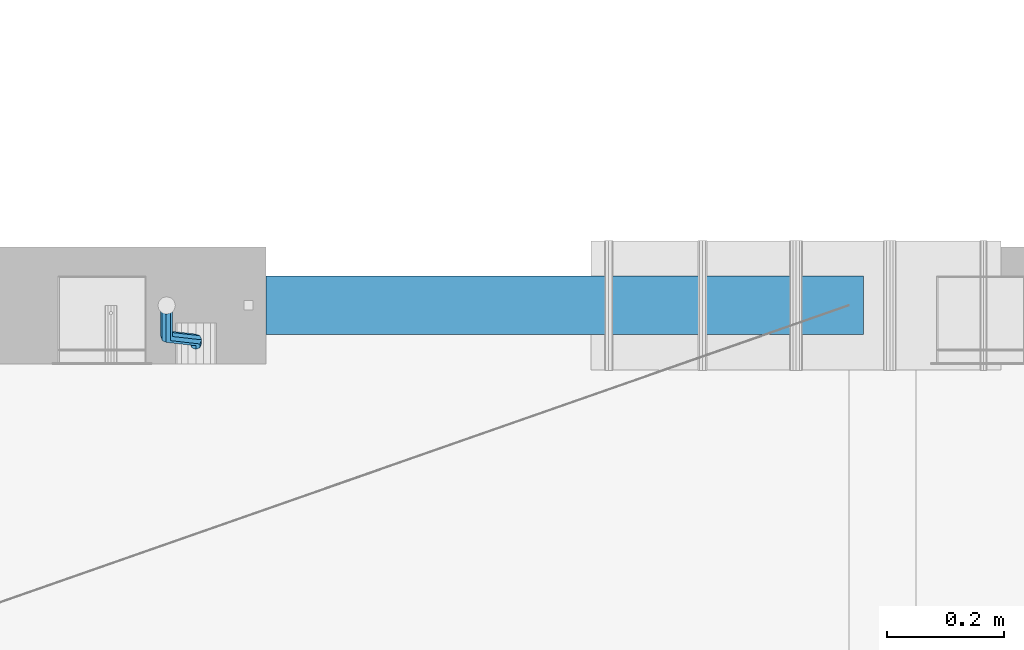
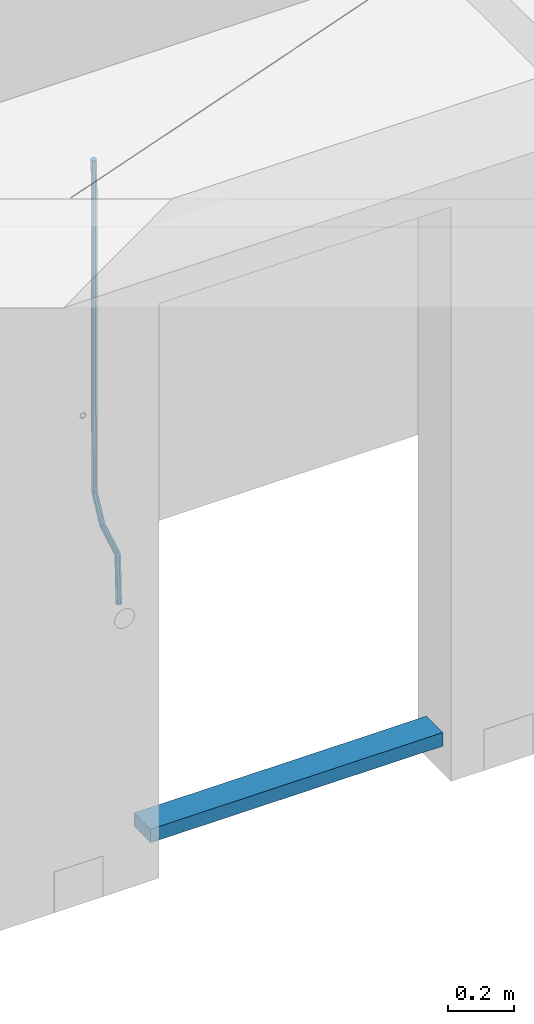
# One storey, part 107 of 341: 2 beams, 1 element without a shape of its own.
"""IFC2X3 building model written with IfcOpenShell, lengths in millimetres."""

from ifc_helpers import new_model, si_unit, frame, origin_with_axes, place, context, subcontext, project, spatial, faceted_brep, material, type_object, element, aggregate, save


model = new_model("IFC2X3")

# Units and contexts
model_context = context("Model", 3, precision=1e-05, world=origin_with_axes())
body_context = subcontext(model_context, "Body", "Model", "MODEL_VIEW")
ifc_project = project(units=[si_unit("LENGTHUNIT", "METRE", prefix="MILLI"), si_unit("AREAUNIT", "SQUARE_METRE"), si_unit("VOLUMEUNIT", "CUBIC_METRE"), si_unit("MASSUNIT", "GRAM", prefix="KILO"), si_unit("TIMEUNIT", "SECOND"), si_unit("PLANEANGLEUNIT", "RADIAN"), si_unit("SOLIDANGLEUNIT", "STERADIAN"), si_unit("THERMODYNAMICTEMPERATUREUNIT", "DEGREE_CELSIUS"), si_unit("LUMINOUSINTENSITYUNIT", "LUMEN")], contexts=[model_context])

# Site, building, storey
site_placement = place(None, origin_with_axes())
site = spatial("IfcSite", under=ifc_project, at=site_placement, CompositionType="ELEMENT")
building_placement = place(site_placement, origin_with_axes())
building = spatial("IfcBuilding", under=site, at=building_placement, CompositionType="ELEMENT")
storey_placement = place(building_placement, origin_with_axes())
storey = spatial("IfcBuildingStorey", under=building, at=storey_placement, Name="5", CompositionType="ELEMENT", Elevation=0.0)

# Assembly, beams
assembly_placement = place(storey_placement, origin_with_axes())
assembly = element("IfcElementAssembly", 1, at=assembly_placement, inside=storey, AssemblyPlace="NOTDEFINED", PredefinedType="REINFORCEMENT_UNIT")
ifc_material_1 = material()
beam_type_1 = type_object("IfcBeamType", Name="D20", PredefinedType="NOTDEFINED")
beam_1_placement = place(assembly_placement, frame((24379.9991455117, 15114.989587991, 94790.0076324386), z_axis=(-0.000205762999925498, 0.999642804629538, -0.0267249099901004), x_axis=(4.30000201928125e-08, 0.0267249099948059, 0.999642825806181)))
beam_1 = element("IfcBeam", 2, at=beam_1_placement, type_object=beam_type_1, material=ifc_material_1, Name="JM20", ObjectType="D20", context=body_context, shape_type="Brep", body=[
    faceted_brep([(0.0, -10.0, 0.0), (-4.19531716033816e-08, -7.07106781186667, -7.07106781187031), (60.4266690400545, -7.0710677960451, -7.07106780570757), (60.4266690441291, -9.99999998418934, 6.15546014159918e-09), (0.0, 0.0, -10.0), (60.426669036824, 1.58106558956206e-08, -9.99999999384454), (4.196772351861e-08, 7.07106781186303, -7.07106781186667), (60.4266690363438, 7.07106782768096, -7.07106780570757), (0.0, 10.0, 0.0), (60.4266690388904, 10.0000000158179, 6.15182216279209e-09), (4.196772351861e-08, 7.07106781185939, 7.07106781185939), (60.4266690429649, 7.07106782768096, 7.07106781802577), (0.0, 0.0, 10.0), (60.4266690461809, 1.58179318532348e-08, 10.0000000061555), (-4.19531716033816e-08, -7.07106781187031, 7.07106781185939), (60.4266690466611, -7.07106779605238, 7.07106781802213), (61.0378400410118, -7.07106779588503, -7.07106780564936), (60.991799419251, -9.99999998403655, 6.21366780251265e-09), (61.0569027789461, 1.5985278878361e-08, -9.99999999378269), (61.0378209396877, 7.07106782784831, -7.07106780564936), (60.9917724058905, 10.0000000159635, 6.21366780251265e-09), (60.9457317841297, 7.07106782781193, 7.0710678180767), (60.9266690461809, 1.59488990902901e-08, 10.0000000062028), (60.9457508854539, -7.07106779591413, 7.0710678180767), (61.6489592143771, -7.07106614513759, -7.06310863441468), (61.5568818710308, -9.9999984576425, 0.00735959856683621), (61.6870830769039, 1.71821739058942e-06, -9.99179257185824), (61.6489210170112, 7.07106947854481, -7.06310888312146), (61.556827851804, 10.0000015422847, 0.00735924683976918), (61.4647505084577, 7.07106922979438, 7.07782747982128), (61.4266266459163, 1.36643211590126e-06, 10.0065114172685), (61.464788705809, -7.07106639389531, 7.07782772852806), (174.621213165461, -7.07076098345351, -5.59176629582907), (174.529135822144, -9.99969329595478, 1.4787019371488), (174.659337027944, 0.000306879905110691, -8.52045023327446), (174.621174967935, 7.07137464022526, -5.59176654453404), (174.529081802684, 10.0003067039688, 1.47870158543083), (174.437004459352, 7.07137439147118, 8.5491698184087), (174.398880596913, 0.000306528108922066, 11.4778537558541), (174.437042656878, -7.07076123221123, 8.54917006711185), (175.716094779258, -7.07075802595864, -5.57750663810293), (175.029093421879, -9.99969194546793, 1.48521334821271), (177.145578432857, 0.000313595744955819, -8.48806960781258), (178.480172245545, 7.07138506415868, -5.54150724740612), (178.938089262141, 10.0003186135946, 1.53612417477052), (178.251087904748, 7.07138469408164, 8.59884416108434), (176.821604251149, 0.000313072378048673, 11.5094071307958), (175.487010438475, -7.07075839603567, 8.56284477038935), (176.73028205616, -7.48306481911277, -5.5575978012148), (175.49220343327, -10.1879642774365, 1.49430435328395), (179.448580299344, -0.935946733912715, -8.44286090764945), (182.054755918522, 5.61817699831226, -5.47133696928722), (183.022146581905, 8.33998958468874, 1.61629559169705), (181.784067959001, 5.63509012636496, 8.6681977461958), (179.065769715831, -0.912027958831459, 11.5534608526305), (176.459594096654, -7.4661516910528, 8.58193691426459), (294.295456565174, -55.2779062578775, -3.24975393820569), (293.057377942285, -57.9828057162013, 3.80214821629306), (297.013754808359, -48.7307881726811, -6.13501704463852), (299.619930427536, -42.1766644404597, -3.16349310627629), (300.587321090919, -39.454851854076, 3.92413945470616), (299.34924246803, -42.1597513124034, 10.9760416092031), (296.630944224846, -48.7068693975998, 13.8613047156396), (294.024768605668, -55.2609931298248, 10.8897807772755), (300.131186042752, -57.6503585272258, -3.13519660847487), (297.927214299008, -59.9625846556301, 3.89774473963917), (302.241773597852, -50.8561822796182, -6.0323892798333), (303.022623399127, -43.5599922135116, -3.09669710035814), (302.016324223136, -40.0357975159677, 3.95219126616212), (299.812352479406, -42.3480236443684, 10.9851326142743), (297.701764924292, -49.1421998919686, 13.8823252856328), (296.920915123032, -56.4383899580826, 10.9466331061594), (305.816309115588, -57.6497962814865, -0.41917616768842), (302.671371672826, -59.9621154692577, 6.16422661461002), (307.334869561208, -50.8556785840192, -3.59920488503303), (306.337500895927, -43.5596643796707, -1.51304184353285), (303.408448157163, -40.0356598380822, 4.61726694041863), (300.263510714387, -42.3479790258461, 11.2006697227207), (298.744950268767, -49.1420967233171, 14.3806984400617), (299.742318934063, -56.4381109276655, 12.2945353985633), (395.630203780689, -57.6409138916788, 42.488667805259), (392.485266337913, -59.9532330794427, 49.0720705875574), (397.148764226309, -50.8467961942151, 39.3086390879143), (396.151395561013, -43.5507819898594, 41.3948021294145), (393.22234282225, -40.0267774482672, 47.5251109133696), (390.077405379474, -42.3390966360348, 54.1085136956717), (388.558844933854, -49.1332143335057, 57.2885424130127), (389.556213599149, -56.4292285378579, 55.2023793715125), (396.844209099741, -57.640793829316, 43.0686487871244), (395.280625423067, -59.9529566247911, 50.4075302279853), (397.599922461304, -50.8467515756856, 39.5241761963625), (397.10507886979, -43.5506876727486, 41.8504164279075), (395.649550989881, -40.0265374029004, 48.6846895034632), (394.085967313207, -42.3387001983865, 56.0235709443259), (393.330253951674, -49.1327424520096, 59.5680435350878), (393.825097543173, -56.4288063549466, 57.241803303541), (398.189189358192, -57.6411602552034, 43.0337942646147), (398.377566371972, -59.9538003541529, 50.3272744790011), (398.099754636642, -50.8468877497689, 39.5112232837091), (398.161651854258, -43.550975525075, 41.8230358424771), (398.338622460418, -40.027270012466, 48.6150034976581), (398.526999474212, -42.3399101114192, 55.9084837120445), (398.616434195777, -49.13418261685, 59.4310546929501), (398.554536978161, -56.4300948415512, 57.1192421341821), (1517.19478070838, -57.9460216934422, 14.0352975759452), (1517.38315772217, -60.2586617923953, 21.3287777903333), (1517.10534598683, -51.1517491880113, 10.5127265950414), (1517.16724320444, -43.8558369633138, 12.8245391538094), (1517.34421381062, -40.3321314507048, 19.6165068089904), (1517.53259082441, -42.6447715496579, 26.9099870233767), (1517.62202554596, -49.4390440550887, 30.4325580042841), (1517.56012832835, -56.7349562797899, 28.1207454455143), (1518.02724982343, -57.946248491, 14.0137245355054), (1518.07759034891, -60.258850983344, 21.3107818997123), (1517.99524544395, -51.1519916318648, 10.4896652746502), (1518.00032494192, -43.8560639277712, 12.8029502375484), (1518.03951281632, -40.3323208776928, 19.5984884665704), (1518.08985334181, -42.6449233700369, 26.8955458307773), (1518.12185772131, -49.4391802291757, 30.4196050916289), (1518.11677822332, -56.735107933262, 28.1063201287325), (1518.85992470267, -57.9437654472204, 14.0245252313944), (1518.77219462092, -60.2567796673247, 21.3197916701429), (1518.8853648605, -51.149337287974, 10.5012110884654), (1518.83361259502, -43.8535790567003, 12.8137588817826), (1518.73498368141, -40.3302469774862, 19.6075094776534), (1518.64725359967, -42.6432611975906, 26.9027759164019), (1518.62181344185, -49.4376893568369, 30.4260900593326), (1518.67356570732, -56.7334475881107, 28.1135422660154), (1618.76572350181, -57.6458454809253, 15.3204117501973), (1618.67799342007, -59.9588597010261, 22.6156781889458), (1618.79116365965, -50.8514173216718, 11.7970976072666), (1618.73941139416, -43.5556590904016, 14.1096454005838), (1618.64078248056, -40.032327011184, 20.9033959964545), (1618.55305239883, -42.3453412312883, 28.198662435203), (1618.52761224099, -49.1397693905419, 31.7219765781338), (1618.57936450648, -56.4355276218121, 29.4094287848166)], [[[0, 1, 2, 3]], [[1, 4, 5, 2]], [[4, 6, 7, 5]], [[6, 8, 9, 7]], [[8, 10, 11, 9]], [[10, 12, 13, 11]], [[12, 14, 15, 13]], [[14, 0, 3, 15]], [[14, 12, 10, 8, 6, 4, 1, 0]], [[3, 2, 16, 17]], [[2, 5, 18, 16]], [[5, 7, 19, 18]], [[7, 9, 20, 19]], [[9, 11, 21, 20]], [[11, 13, 22, 21]], [[13, 15, 23, 22]], [[15, 3, 17, 23]], [[17, 16, 24, 25]], [[16, 18, 26, 24]], [[18, 19, 27, 26]], [[19, 20, 28, 27]], [[20, 21, 29, 28]], [[21, 22, 30, 29]], [[22, 23, 31, 30]], [[23, 17, 25, 31]], [[25, 24, 32, 33]], [[24, 26, 34, 32]], [[26, 27, 35, 34]], [[27, 28, 36, 35]], [[28, 29, 37, 36]], [[29, 30, 38, 37]], [[30, 31, 39, 38]], [[31, 25, 33, 39]], [[33, 32, 40, 41]], [[32, 34, 42, 40]], [[34, 35, 43, 42]], [[35, 36, 44, 43]], [[36, 37, 45, 44]], [[37, 38, 46, 45]], [[38, 39, 47, 46]], [[39, 33, 41, 47]], [[41, 40, 48, 49]], [[40, 42, 50, 48]], [[42, 43, 51, 50]], [[43, 44, 52, 51]], [[44, 45, 53, 52]], [[45, 46, 54, 53]], [[46, 47, 55, 54]], [[47, 41, 49, 55]], [[49, 48, 56, 57]], [[48, 50, 58, 56]], [[50, 51, 59, 58]], [[51, 52, 60, 59]], [[52, 53, 61, 60]], [[53, 54, 62, 61]], [[54, 55, 63, 62]], [[55, 49, 57, 63]], [[57, 56, 64, 65]], [[56, 58, 66, 64]], [[58, 59, 67, 66]], [[59, 60, 68, 67]], [[60, 61, 69, 68]], [[61, 62, 70, 69]], [[62, 63, 71, 70]], [[63, 57, 65, 71]], [[65, 64, 72, 73]], [[64, 66, 74, 72]], [[66, 67, 75, 74]], [[67, 68, 76, 75]], [[68, 69, 77, 76]], [[69, 70, 78, 77]], [[70, 71, 79, 78]], [[71, 65, 73, 79]], [[73, 72, 80, 81]], [[72, 74, 82, 80]], [[74, 75, 83, 82]], [[75, 76, 84, 83]], [[76, 77, 85, 84]], [[77, 78, 86, 85]], [[78, 79, 87, 86]], [[79, 73, 81, 87]], [[81, 80, 88, 89]], [[80, 82, 90, 88]], [[82, 83, 91, 90]], [[83, 84, 92, 91]], [[84, 85, 93, 92]], [[85, 86, 94, 93]], [[86, 87, 95, 94]], [[87, 81, 89, 95]], [[89, 88, 96, 97]], [[88, 90, 98, 96]], [[90, 91, 99, 98]], [[91, 92, 100, 99]], [[92, 93, 101, 100]], [[93, 94, 102, 101]], [[94, 95, 103, 102]], [[95, 89, 97, 103]], [[97, 96, 104, 105]], [[96, 98, 106, 104]], [[98, 99, 107, 106]], [[99, 100, 108, 107]], [[100, 101, 109, 108]], [[101, 102, 110, 109]], [[102, 103, 111, 110]], [[103, 97, 105, 111]], [[105, 104, 112, 113]], [[104, 106, 114, 112]], [[106, 107, 115, 114]], [[107, 108, 116, 115]], [[108, 109, 117, 116]], [[109, 110, 118, 117]], [[110, 111, 119, 118]], [[111, 105, 113, 119]], [[113, 112, 120, 121]], [[112, 114, 122, 120]], [[114, 115, 123, 122]], [[115, 116, 124, 123]], [[116, 117, 125, 124]], [[117, 118, 126, 125]], [[118, 119, 127, 126]], [[119, 113, 121, 127]], [[121, 120, 128, 129]], [[120, 122, 130, 128]], [[122, 123, 131, 130]], [[123, 124, 132, 131]], [[124, 125, 133, 132]], [[125, 126, 134, 133]], [[126, 127, 135, 134]], [[127, 121, 129, 135]], [[130, 131, 132, 133, 134, 135, 129, 128]]]),
])
ifc_material_2 = material(Name="TIMBER/T24")
beam_type_2 = type_object("IfcBeamType", PredefinedType="NOTDEFINED")
beam_2_placement = place(assembly_placement, frame((24500.0006866455, 15180.0, 93880.0), z_axis=(0.0, 0.0, 1.0), x_axis=(1.0, 0.0, 0.0)))
beam_2 = element("IfcBeam", 3, at=beam_2_placement, type_object=beam_type_2, material=ifc_material_2, context=body_context, shape_type="Brep", body=[
    faceted_brep([(0.0, 50.0, -25.0), (0.0, 50.0, 25.0), (1020.0, 50.0, 25.0), (1020.0, 50.0, -25.0), (0.0, -50.0, 25.0), (1020.0, -50.0, 25.0), (0.0, -50.0, -25.0), (1020.0, -50.0, -25.0)], [[[0, 1, 2, 3]], [[1, 4, 5, 2]], [[4, 6, 7, 5]], [[6, 0, 3, 7]], [[5, 7, 3, 2]], [[6, 4, 1, 0]]]),
])
aggregate(assembly, [beam_1, beam_2])

save(model, "model.ifc")
